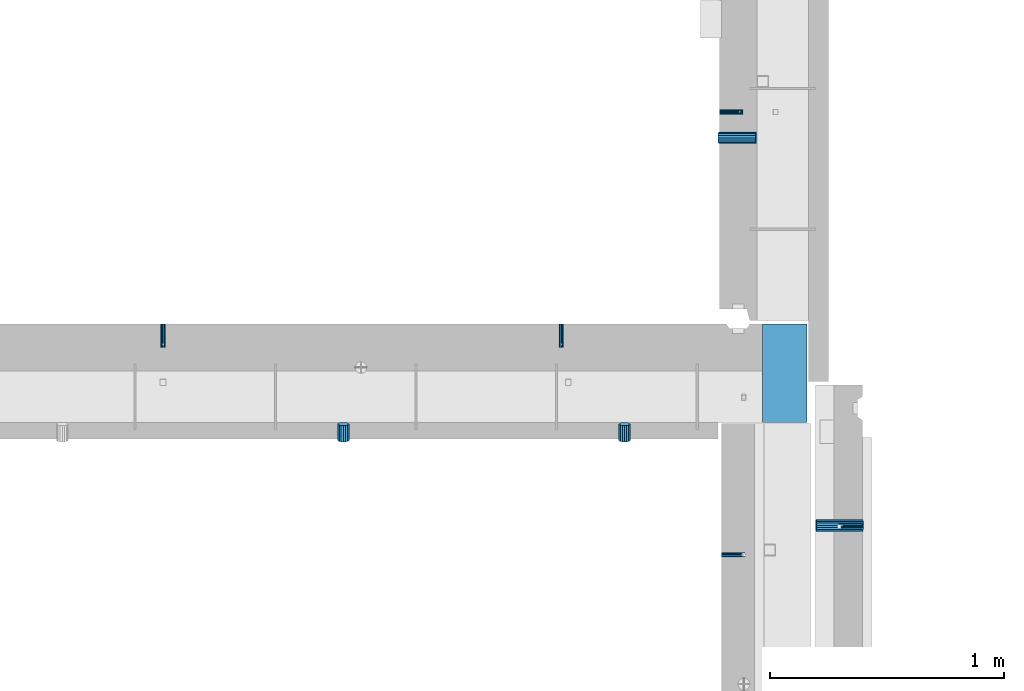
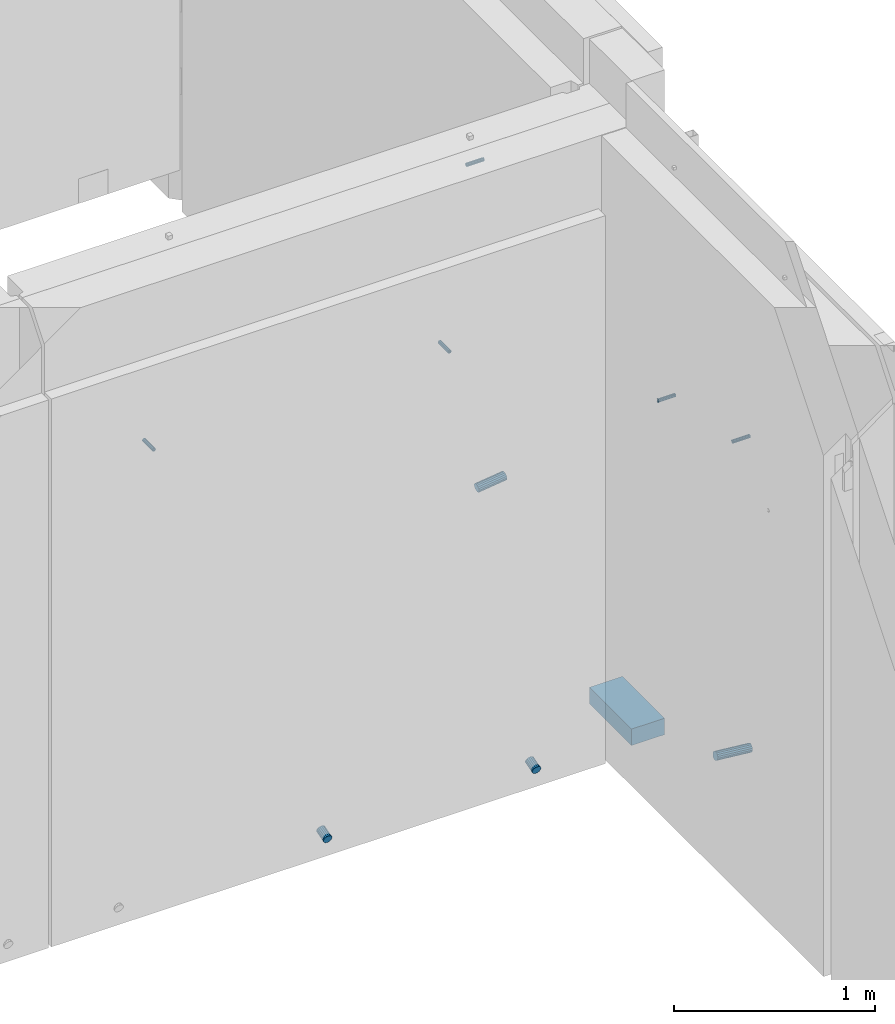
# One storey, part 111 of 264: 10 beams, 13 elements without a shape of their own.
"""IFC2X3 building model written with IfcOpenShell, lengths in millimetres."""

from ifc_helpers import new_model, si_unit, frame, origin_with_axes, place, context, subcontext, project, spatial, faceted_brep, material, type_object, element, aggregate, save


model = new_model("IFC2X3")

# Units and contexts
model_context = context("Model", 3, precision=1e-05, world=origin_with_axes())
body_context = subcontext(model_context, "Body", "Model", "MODEL_VIEW")
ifc_project = project(units=[si_unit("LENGTHUNIT", "METRE", prefix="MILLI"), si_unit("AREAUNIT", "SQUARE_METRE"), si_unit("VOLUMEUNIT", "CUBIC_METRE"), si_unit("MASSUNIT", "GRAM", prefix="KILO"), si_unit("TIMEUNIT", "SECOND"), si_unit("PLANEANGLEUNIT", "RADIAN"), si_unit("SOLIDANGLEUNIT", "STERADIAN"), si_unit("THERMODYNAMICTEMPERATUREUNIT", "DEGREE_CELSIUS"), si_unit("LUMINOUSINTENSITYUNIT", "LUMEN")], contexts=[model_context])

# Site, building, storey
site_placement = place(None, origin_with_axes())
site = spatial("IfcSite", under=ifc_project, at=site_placement, CompositionType="ELEMENT")
building_placement = place(site_placement, origin_with_axes())
building = spatial("IfcBuilding", under=site, at=building_placement, CompositionType="ELEMENT")
storey_placement = place(building_placement, origin_with_axes())
storey = spatial("IfcBuildingStorey", under=building, at=storey_placement, Name="K", CompositionType="ELEMENT", Elevation=0.0)

# Assemblies, beam
assembly_1_placement = place(storey_placement, origin_with_axes())
assembly_1 = element("IfcElementAssembly", 1, at=assembly_1_placement, inside=storey, AssemblyPlace="NOTDEFINED", PredefinedType="REINFORCEMENT_UNIT")
assembly_2_placement = place(assembly_1_placement, origin_with_axes())
assembly_2 = element("IfcElementAssembly", 2, at=assembly_2_placement, Name="Steel Assembly", AssemblyPlace="NOTDEFINED", PredefinedType="RIGID_FRAME")
ifc_material_1 = material(Name="STEEL/Steel_Undefined")
beam_type_1 = type_object("IfcBeamType", PredefinedType="NOTDEFINED")
beam_1_placement = place(assembly_2_placement, frame((35510.0000014901, 12319.9848274528, 79700.0030770672), z_axis=(0.0, 1.0, 0.0), x_axis=(-1.0, 3.00000001838171e-08, 0.0)))
beam_1 = element("IfcBeam", 3, at=beam_1_placement, type_object=beam_type_1, material=ifc_material_1, Name="M16", context=body_context, shape_type="Brep", body=[
    faceted_brep([(0.0, -8.49999999999272, -1.45519152283669e-11), (0.0, -7.36121593215648, 4.24999999998545), (100.000000000262, -7.36121593215648, 4.24999999998545), (100.000000000262, -8.49999999999272, -1.45519152283669e-11), (0.0, -4.24999999998545, 7.36121593216376), (100.000000000262, -4.24999999998545, 7.36121593216376), (0.0, 1.45519152283669e-11, 8.49999999998545), (100.000000000262, 1.45519152283669e-11, 8.49999999998545), (0.0, 4.25000000001455, 7.36121593216376), (100.000000000262, 4.25000000001455, 7.36121593216376), (0.0, 7.36121593217104, 4.24999999998545), (100.000000000262, 7.36121593217104, 4.24999999998545), (0.0, 8.50000000000728, 0.0), (100.000000000262, 8.50000000000728, 0.0), (0.0, 7.36121593217104, -4.25000000001455), (100.000000000262, 7.36121593217104, -4.25000000001455), (0.0, 4.25000000000728, -7.36121593219286), (100.000000000262, 4.25000000000728, -7.36121593219286), (0.0, 7.27595761418343e-12, -8.5), (100.000000000262, 7.27595761418343e-12, -8.5), (0.0, -4.24999999999272, -7.36121593217831), (100.000000000262, -4.24999999999272, -7.36121593217831), (0.0, -7.36121593215648, -4.25), (100.000000000262, -7.36121593215648, -4.25), (0.0, -10.4999999999927, -1.45519152283669e-11), (0.0, -9.09326673972828, -5.25000000001455), (100.000000000262, -9.09326673972828, -5.25000000001455), (100.000000000262, -10.4999999999927, -1.45519152283669e-11), (0.0, -5.24999999998545, -9.09326673974283), (100.000000000262, -5.24999999998545, -9.09326673974283), (0.0, 7.27595761418343e-12, -10.5), (100.000000000262, 7.27595761418343e-12, -10.5), (0.0, 5.25000000001455, -9.09326673975738), (100.000000000262, 5.25000000001455, -9.09326673975738), (0.0, 9.09326673975011, -5.25000000001455), (100.000000000262, 9.09326673975011, -5.25000000001455), (0.0, 10.5000000000073, -1.45519152283669e-11), (100.000000000262, 10.5000000000073, -1.45519152283669e-11), (0.0, 9.09326673975011, 5.25), (100.000000000262, 9.09326673975011, 5.25), (0.0, 5.25000000000728, 9.09326673972828), (100.000000000262, 5.25000000000728, 9.09326673972828), (0.0, 1.45519152283669e-11, 10.4999999999854), (100.000000000262, 1.45519152283669e-11, 10.4999999999854), (0.0, -5.24999999999272, 9.09326673972828), (100.000000000262, -5.24999999999272, 9.09326673972828), (0.0, -9.09326673972828, 5.24999999998545), (100.000000000262, -9.09326673972828, 5.24999999998545)], [[[0, 1, 2, 3]], [[1, 4, 5, 2]], [[4, 6, 7, 5]], [[6, 8, 9, 7]], [[8, 10, 11, 9]], [[10, 12, 13, 11]], [[12, 14, 15, 13]], [[14, 16, 17, 15]], [[16, 18, 19, 17]], [[18, 20, 21, 19]], [[20, 22, 23, 21]], [[22, 0, 3, 23]], [[24, 25, 26, 27]], [[25, 28, 29, 26]], [[28, 30, 31, 29]], [[30, 32, 33, 31]], [[32, 34, 35, 33]], [[34, 36, 37, 35]], [[36, 38, 39, 37]], [[38, 40, 41, 39]], [[40, 42, 43, 41]], [[42, 44, 45, 43]], [[44, 46, 47, 45]], [[46, 24, 27, 47]], [[29, 31, 33, 35, 37, 39, 41, 43, 45, 47, 27, 26], [5, 7, 9, 11, 13, 15, 17, 19, 21, 23, 3, 2]], [[46, 44, 42, 40, 38, 36, 34, 32, 30, 28, 25, 24], [22, 20, 18, 16, 14, 12, 10, 8, 6, 4, 1, 0]]]),
])
aggregate(assembly_2, [beam_1])

# Assemblies, beams
assembly_3_placement = place(storey_placement, origin_with_axes())
assembly_3 = element("IfcElementAssembly", 4, at=assembly_3_placement, inside=storey, AssemblyPlace="NOTDEFINED", PredefinedType="REINFORCEMENT_UNIT")
assembly_4_placement = place(assembly_3_placement, origin_with_axes())
assembly_4 = element("IfcElementAssembly", 5, at=assembly_4_placement, Name="Steel Assembly", AssemblyPlace="NOTDEFINED", PredefinedType="RIGID_FRAME")
beam_2_placement = place(assembly_4_placement, frame((32525.0017535345, 13180.0018965848, 80200.0), z_axis=(-1.0, 3.00000001838171e-08, 0.0), x_axis=(0.0, -1.0, 0.0)))
beam_2 = element("IfcBeam", 6, at=beam_2_placement, type_object=beam_type_1, material=ifc_material_1, Name="M16", context=body_context, shape_type="Brep", body=[
    faceted_brep([(0.0, -8.49999999999272, -1.45519152283669e-11), (0.0, -7.36121593215648, 4.24999999998545), (100.000000000262, -7.36121593215648, 4.24999999998545), (100.000000000262, -8.49999999999272, -1.45519152283669e-11), (0.0, -4.24999999998545, 7.36121593216376), (100.000000000262, -4.24999999998545, 7.36121593216376), (0.0, 1.45519152283669e-11, 8.49999999998545), (100.000000000262, 1.45519152283669e-11, 8.49999999998545), (0.0, 4.25000000001455, 7.36121593216376), (100.000000000262, 4.25000000001455, 7.36121593216376), (0.0, 7.36121593217104, 4.24999999998545), (100.000000000262, 7.36121593217104, 4.24999999998545), (0.0, 8.50000000000728, 0.0), (100.000000000262, 8.50000000000728, 0.0), (0.0, 7.36121593217104, -4.25000000001455), (100.000000000262, 7.36121593217104, -4.25000000001455), (0.0, 4.25000000000728, -7.36121593219286), (100.000000000262, 4.25000000000728, -7.36121593219286), (0.0, 7.27595761418343e-12, -8.5), (100.000000000262, 7.27595761418343e-12, -8.5), (0.0, -4.24999999999272, -7.36121593217831), (100.000000000262, -4.24999999999272, -7.36121593217831), (0.0, -7.36121593215648, -4.25), (100.000000000262, -7.36121593215648, -4.25), (0.0, -10.4999999999927, -1.45519152283669e-11), (0.0, -9.09326673972828, -5.25000000001455), (100.000000000262, -9.09326673972828, -5.25000000001455), (100.000000000262, -10.4999999999927, -1.45519152283669e-11), (0.0, -5.24999999998545, -9.09326673974283), (100.000000000262, -5.24999999998545, -9.09326673974283), (0.0, 7.27595761418343e-12, -10.5), (100.000000000262, 7.27595761418343e-12, -10.5), (0.0, 5.25000000001455, -9.09326673975738), (100.000000000262, 5.25000000001455, -9.09326673975738), (0.0, 9.09326673975011, -5.25000000001455), (100.000000000262, 9.09326673975011, -5.25000000001455), (0.0, 10.5000000000073, -1.45519152283669e-11), (100.000000000262, 10.5000000000073, -1.45519152283669e-11), (0.0, 9.09326673975011, 5.25), (100.000000000262, 9.09326673975011, 5.25), (0.0, 5.25000000000728, 9.09326673972828), (100.000000000262, 5.25000000000728, 9.09326673972828), (0.0, 1.45519152283669e-11, 10.4999999999854), (100.000000000262, 1.45519152283669e-11, 10.4999999999854), (0.0, -5.24999999999272, 9.09326673972828), (100.000000000262, -5.24999999999272, 9.09326673972828), (0.0, -9.09326673972828, 5.24999999998545), (100.000000000262, -9.09326673972828, 5.24999999998545)], [[[0, 1, 2, 3]], [[1, 4, 5, 2]], [[4, 6, 7, 5]], [[6, 8, 9, 7]], [[8, 10, 11, 9]], [[10, 12, 13, 11]], [[12, 14, 15, 13]], [[14, 16, 17, 15]], [[16, 18, 19, 17]], [[18, 20, 21, 19]], [[20, 22, 23, 21]], [[22, 0, 3, 23]], [[24, 25, 26, 27]], [[25, 28, 29, 26]], [[28, 30, 31, 29]], [[30, 32, 33, 31]], [[32, 34, 35, 33]], [[34, 36, 37, 35]], [[36, 38, 39, 37]], [[38, 40, 41, 39]], [[40, 42, 43, 41]], [[42, 44, 45, 43]], [[44, 46, 47, 45]], [[46, 24, 27, 47]], [[29, 31, 33, 35, 37, 39, 41, 43, 45, 47, 27, 26], [5, 7, 9, 11, 13, 15, 17, 19, 21, 23, 3, 2]], [[46, 44, 42, 40, 38, 36, 34, 32, 30, 28, 25, 24], [22, 20, 18, 16, 14, 12, 10, 8, 6, 4, 1, 0]]]),
])
aggregate(assembly_4, [beam_2])
assembly_5_placement = place(assembly_3_placement, origin_with_axes())
assembly_5 = element("IfcElementAssembly", 7, at=assembly_5_placement, Name="Steel Assembly", AssemblyPlace="NOTDEFINED", PredefinedType="RIGID_FRAME")
beam_3_placement = place(assembly_5_placement, frame((34225.0017535345, 13180.0018965848, 80200.0), z_axis=(1.0, 0.0, 0.0), x_axis=(0.0, -1.0, 0.0)))
beam_3 = element("IfcBeam", 8, at=beam_3_placement, type_object=beam_type_1, material=ifc_material_1, Name="M16", context=body_context, shape_type="Brep", body=[
    faceted_brep([(0.0, -8.49999999999272, -1.45519152283669e-11), (0.0, -7.36121593215648, 4.24999999998545), (100.000000000262, -7.36121593215648, 4.24999999998545), (100.000000000262, -8.49999999999272, -1.45519152283669e-11), (0.0, -4.24999999998545, 7.36121593216376), (100.000000000262, -4.24999999998545, 7.36121593216376), (0.0, 1.45519152283669e-11, 8.49999999998545), (100.000000000262, 1.45519152283669e-11, 8.49999999998545), (0.0, 4.25000000001455, 7.36121593216376), (100.000000000262, 4.25000000001455, 7.36121593216376), (0.0, 7.36121593217104, 4.24999999998545), (100.000000000262, 7.36121593217104, 4.24999999998545), (0.0, 8.50000000000728, 0.0), (100.000000000262, 8.50000000000728, 0.0), (0.0, 7.36121593217104, -4.25000000001455), (100.000000000262, 7.36121593217104, -4.25000000001455), (0.0, 4.25000000000728, -7.36121593219286), (100.000000000262, 4.25000000000728, -7.36121593219286), (0.0, 7.27595761418343e-12, -8.5), (100.000000000262, 7.27595761418343e-12, -8.5), (0.0, -4.24999999999272, -7.36121593217831), (100.000000000262, -4.24999999999272, -7.36121593217831), (0.0, -7.36121593215648, -4.25), (100.000000000262, -7.36121593215648, -4.25), (0.0, -10.4999999999927, -1.45519152283669e-11), (0.0, -9.09326673972828, -5.25000000001455), (100.000000000262, -9.09326673972828, -5.25000000001455), (100.000000000262, -10.4999999999927, -1.45519152283669e-11), (0.0, -5.24999999998545, -9.09326673974283), (100.000000000262, -5.24999999998545, -9.09326673974283), (0.0, 7.27595761418343e-12, -10.5), (100.000000000262, 7.27595761418343e-12, -10.5), (0.0, 5.25000000001455, -9.09326673975738), (100.000000000262, 5.25000000001455, -9.09326673975738), (0.0, 9.09326673975011, -5.25000000001455), (100.000000000262, 9.09326673975011, -5.25000000001455), (0.0, 10.5000000000073, -1.45519152283669e-11), (100.000000000262, 10.5000000000073, -1.45519152283669e-11), (0.0, 9.09326673975011, 5.25), (100.000000000262, 9.09326673975011, 5.25), (0.0, 5.25000000000728, 9.09326673972828), (100.000000000262, 5.25000000000728, 9.09326673972828), (0.0, 1.45519152283669e-11, 10.4999999999854), (100.000000000262, 1.45519152283669e-11, 10.4999999999854), (0.0, -5.24999999999272, 9.09326673972828), (100.000000000262, -5.24999999999272, 9.09326673972828), (0.0, -9.09326673972828, 5.24999999998545), (100.000000000262, -9.09326673972828, 5.24999999998545)], [[[0, 1, 2, 3]], [[1, 4, 5, 2]], [[4, 6, 7, 5]], [[6, 8, 9, 7]], [[8, 10, 11, 9]], [[10, 12, 13, 11]], [[12, 14, 15, 13]], [[14, 16, 17, 15]], [[16, 18, 19, 17]], [[18, 20, 21, 19]], [[20, 22, 23, 21]], [[22, 0, 3, 23]], [[24, 25, 26, 27]], [[25, 28, 29, 26]], [[28, 30, 31, 29]], [[30, 32, 33, 31]], [[32, 34, 35, 33]], [[34, 36, 37, 35]], [[36, 38, 39, 37]], [[38, 40, 41, 39]], [[40, 42, 43, 41]], [[42, 44, 45, 43]], [[44, 46, 47, 45]], [[46, 24, 27, 47]], [[29, 31, 33, 35, 37, 39, 41, 43, 45, 47, 27, 26], [5, 7, 9, 11, 13, 15, 17, 19, 21, 23, 3, 2]], [[46, 44, 42, 40, 38, 36, 34, 32, 30, 28, 25, 24], [22, 20, 18, 16, 14, 12, 10, 8, 6, 4, 1, 0]]]),
])
aggregate(assembly_5, [beam_3])

# Assemblies, beam
assembly_6_placement = place(storey_placement, origin_with_axes())
assembly_6 = element("IfcElementAssembly", 9, at=assembly_6_placement, inside=storey, AssemblyPlace="NOTDEFINED", PredefinedType="REINFORCEMENT_UNIT")
assembly_7_placement = place(assembly_6_placement, origin_with_axes())
assembly_7 = element("IfcElementAssembly", 10, at=assembly_7_placement, Name="Steel Assembly", AssemblyPlace="NOTDEFINED", PredefinedType="RIGID_FRAME")
aggregate(assembly_6, [assembly_7])
beam_4_placement = place(assembly_7_placement, frame((34910.0024573137, 12195.0054710417, 80200.0), z_axis=(0.0, 1.0, 0.0), x_axis=(1.0, 0.0, 0.0)))
beam_4 = element("IfcBeam", 11, at=beam_4_placement, type_object=beam_type_1, material=ifc_material_1, Name="M16", context=body_context, shape_type="Brep", body=[
    faceted_brep([(0.0, -8.49999999999272, -1.45519152283669e-11), (0.0, -7.36121593215648, 4.24999999998545), (100.000000000262, -7.36121593215648, 4.24999999998545), (100.000000000262, -8.49999999999272, -1.45519152283669e-11), (0.0, -4.24999999998545, 7.36121593216376), (100.000000000262, -4.24999999998545, 7.36121593216376), (0.0, 1.45519152283669e-11, 8.49999999998545), (100.000000000262, 1.45519152283669e-11, 8.49999999998545), (0.0, 4.25000000001455, 7.36121593216376), (100.000000000262, 4.25000000001455, 7.36121593216376), (0.0, 7.36121593217104, 4.24999999998545), (100.000000000262, 7.36121593217104, 4.24999999998545), (0.0, 8.50000000000728, 0.0), (100.000000000262, 8.50000000000728, 0.0), (0.0, 7.36121593217104, -4.25000000001455), (100.000000000262, 7.36121593217104, -4.25000000001455), (0.0, 4.25000000000728, -7.36121593219286), (100.000000000262, 4.25000000000728, -7.36121593219286), (0.0, 7.27595761418343e-12, -8.5), (100.000000000262, 7.27595761418343e-12, -8.5), (0.0, -4.24999999999272, -7.36121593217831), (100.000000000262, -4.24999999999272, -7.36121593217831), (0.0, -7.36121593215648, -4.25), (100.000000000262, -7.36121593215648, -4.25), (0.0, -10.4999999999927, -1.45519152283669e-11), (0.0, -9.09326673972828, -5.25000000001455), (100.000000000262, -9.09326673972828, -5.25000000001455), (100.000000000262, -10.4999999999927, -1.45519152283669e-11), (0.0, -5.24999999998545, -9.09326673974283), (100.000000000262, -5.24999999998545, -9.09326673974283), (0.0, 7.27595761418343e-12, -10.5), (100.000000000262, 7.27595761418343e-12, -10.5), (0.0, 5.25000000001455, -9.09326673975738), (100.000000000262, 5.25000000001455, -9.09326673975738), (0.0, 9.09326673975011, -5.25000000001455), (100.000000000262, 9.09326673975011, -5.25000000001455), (0.0, 10.5000000000073, -1.45519152283669e-11), (100.000000000262, 10.5000000000073, -1.45519152283669e-11), (0.0, 9.09326673975011, 5.25), (100.000000000262, 9.09326673975011, 5.25), (0.0, 5.25000000000728, 9.09326673972828), (100.000000000262, 5.25000000000728, 9.09326673972828), (0.0, 1.45519152283669e-11, 10.4999999999854), (100.000000000262, 1.45519152283669e-11, 10.4999999999854), (0.0, -5.24999999999272, 9.09326673972828), (100.000000000262, -5.24999999999272, 9.09326673972828), (0.0, -9.09326673972828, 5.24999999998545), (100.000000000262, -9.09326673972828, 5.24999999998545)], [[[0, 1, 2, 3]], [[1, 4, 5, 2]], [[4, 6, 7, 5]], [[6, 8, 9, 7]], [[8, 10, 11, 9]], [[10, 12, 13, 11]], [[12, 14, 15, 13]], [[14, 16, 17, 15]], [[16, 18, 19, 17]], [[18, 20, 21, 19]], [[20, 22, 23, 21]], [[22, 0, 3, 23]], [[24, 25, 26, 27]], [[25, 28, 29, 26]], [[28, 30, 31, 29]], [[30, 32, 33, 31]], [[32, 34, 35, 33]], [[34, 36, 37, 35]], [[36, 38, 39, 37]], [[38, 40, 41, 39]], [[40, 42, 43, 41]], [[42, 44, 45, 43]], [[44, 46, 47, 45]], [[46, 24, 27, 47]], [[29, 31, 33, 35, 37, 39, 41, 43, 45, 47, 27, 26], [5, 7, 9, 11, 13, 15, 17, 19, 21, 23, 3, 2]], [[46, 44, 42, 40, 38, 36, 34, 32, 30, 28, 25, 24], [22, 20, 18, 16, 14, 12, 10, 8, 6, 4, 1, 0]]]),
])
aggregate(assembly_7, [beam_4])

assembly_8_placement = place(storey_placement, origin_with_axes())
assembly_8 = element("IfcElementAssembly", 12, at=assembly_8_placement, inside=storey, AssemblyPlace="NOTDEFINED", PredefinedType="REINFORCEMENT_UNIT")
assembly_9_placement = place(assembly_8_placement, origin_with_axes())
assembly_9 = element("IfcElementAssembly", 13, at=assembly_9_placement, Name="Steel Assembly", AssemblyPlace="NOTDEFINED", PredefinedType="RIGID_FRAME")
beam_5_placement = place(assembly_9_placement, frame((34900.0015572397, 14084.9987815364, 80490.0), z_axis=(0.0, -1.0, 0.0), x_axis=(1.0, 0.0, 0.0)))
beam_5 = element("IfcBeam", 14, at=beam_5_placement, type_object=beam_type_1, material=ifc_material_1, Name="M16", context=body_context, shape_type="Brep", body=[
    faceted_brep([(0.0, -8.49999999999272, -1.45519152283669e-11), (0.0, -7.36121593215648, 4.24999999998545), (100.000000000262, -7.36121593215648, 4.24999999998545), (100.000000000262, -8.49999999999272, -1.45519152283669e-11), (0.0, -4.24999999998545, 7.36121593216376), (100.000000000262, -4.24999999998545, 7.36121593216376), (0.0, 1.45519152283669e-11, 8.49999999998545), (100.000000000262, 1.45519152283669e-11, 8.49999999998545), (0.0, 4.25000000001455, 7.36121593216376), (100.000000000262, 4.25000000001455, 7.36121593216376), (0.0, 7.36121593217104, 4.24999999998545), (100.000000000262, 7.36121593217104, 4.24999999998545), (0.0, 8.50000000000728, 0.0), (100.000000000262, 8.50000000000728, 0.0), (0.0, 7.36121593217104, -4.25000000001455), (100.000000000262, 7.36121593217104, -4.25000000001455), (0.0, 4.25000000000728, -7.36121593219286), (100.000000000262, 4.25000000000728, -7.36121593219286), (0.0, 7.27595761418343e-12, -8.5), (100.000000000262, 7.27595761418343e-12, -8.5), (0.0, -4.24999999999272, -7.36121593217831), (100.000000000262, -4.24999999999272, -7.36121593217831), (0.0, -7.36121593215648, -4.25), (100.000000000262, -7.36121593215648, -4.25), (0.0, -10.4999999999927, -1.45519152283669e-11), (0.0, -9.09326673972828, -5.25000000001455), (100.000000000262, -9.09326673972828, -5.25000000001455), (100.000000000262, -10.4999999999927, -1.45519152283669e-11), (0.0, -5.24999999998545, -9.09326673974283), (100.000000000262, -5.24999999998545, -9.09326673974283), (0.0, 7.27595761418343e-12, -10.5), (100.000000000262, 7.27595761418343e-12, -10.5), (0.0, 5.25000000001455, -9.09326673975738), (100.000000000262, 5.25000000001455, -9.09326673975738), (0.0, 9.09326673975011, -5.25000000001455), (100.000000000262, 9.09326673975011, -5.25000000001455), (0.0, 10.5000000000073, -1.45519152283669e-11), (100.000000000262, 10.5000000000073, -1.45519152283669e-11), (0.0, 9.09326673975011, 5.25), (100.000000000262, 9.09326673975011, 5.25), (0.0, 5.25000000000728, 9.09326673972828), (100.000000000262, 5.25000000000728, 9.09326673972828), (0.0, 1.45519152283669e-11, 10.4999999999854), (100.000000000262, 1.45519152283669e-11, 10.4999999999854), (0.0, -5.24999999999272, 9.09326673972828), (100.000000000262, -5.24999999999272, 9.09326673972828), (0.0, -9.09326673972828, 5.24999999998545), (100.000000000262, -9.09326673972828, 5.24999999998545)], [[[0, 1, 2, 3]], [[1, 4, 5, 2]], [[4, 6, 7, 5]], [[6, 8, 9, 7]], [[8, 10, 11, 9]], [[10, 12, 13, 11]], [[12, 14, 15, 13]], [[14, 16, 17, 15]], [[16, 18, 19, 17]], [[18, 20, 21, 19]], [[20, 22, 23, 21]], [[22, 0, 3, 23]], [[24, 25, 26, 27]], [[25, 28, 29, 26]], [[28, 30, 31, 29]], [[30, 32, 33, 31]], [[32, 34, 35, 33]], [[34, 36, 37, 35]], [[36, 38, 39, 37]], [[38, 40, 41, 39]], [[40, 42, 43, 41]], [[42, 44, 45, 43]], [[44, 46, 47, 45]], [[46, 24, 27, 47]], [[29, 31, 33, 35, 37, 39, 41, 43, 45, 47, 27, 26], [5, 7, 9, 11, 13, 15, 17, 19, 21, 23, 3, 2]], [[46, 44, 42, 40, 38, 36, 34, 32, 30, 28, 25, 24], [22, 20, 18, 16, 14, 12, 10, 8, 6, 4, 1, 0]]]),
])
aggregate(assembly_9, [beam_5])

# Assembly
assembly_10_placement = place(assembly_1_placement, origin_with_axes())
assembly_10 = element("IfcElementAssembly", 15, at=assembly_10_placement, Name="Steel Assembly", AssemblyPlace="NOTDEFINED", PredefinedType="NOTDEFINED")

aggregate(assembly_1, [assembly_2, assembly_10])

# Beam
ifc_material_2 = material()
beam_type_2 = type_object("IfcBeamType", Name="D50", PredefinedType="NOTDEFINED")
beam_6_placement = place(assembly_10_placement, frame((35312.4900502895, 12319.99189658, 77824.8759297562), z_axis=(0.0, 1.0, 0.0), x_axis=(0.995037190209988, 0.0, -0.0995037190210061)))
beam_6 = element("IfcBeam", 16, at=beam_6_placement, type_object=beam_type_2, material=ifc_material_2, ObjectType="D50", context=body_context, shape_type="Brep", body=[
    faceted_brep([(0.0, -25.0, 0.0), (-3.63797880709171e-12, -23.0969883127837, -9.56708580912891), (200.997512422258, -23.0969883127982, -9.56708580912709), (200.997512422255, -25.0, 0.0), (-3.63797880709171e-12, -17.6776695296576, -17.6776695296649), (200.997512422262, -17.6776695296867, -17.6776695296639), (-1.09139364212751e-11, -9.56708580913255, -23.0969883127837), (200.997512422262, -9.5670858091471, -23.0969883127818), (-1.09139364212751e-11, 0.0, -25.0), (200.997512422258, -1.45519152283669e-11, -25.0), (-1.09139364212751e-11, 9.56708580913255, -23.0969883127837), (200.997512422262, 9.56708580910345, -23.0969883127818), (-3.63797880709171e-12, 17.6776695296576, -17.6776695296649), (200.997512422262, 17.677669529643, -17.6776695296639), (-3.63797880709171e-12, 23.0969883127837, -9.56708580912891), (200.997512422262, 23.0969883127691, -9.56708580912709), (0.0, 25.0, 0.0), (200.997512422266, 24.9999999999854, 0.0), (7.27595761418343e-12, 23.0969883127837, 9.56708580912891), (200.997512422262, 23.0969883127691, 9.56708580912709), (7.27595761418343e-12, 17.6776695296576, 17.6776695296649), (200.997512422262, 17.677669529643, 17.6776695296639), (1.45519152283669e-11, 9.56708580913255, 23.0969883127837), (200.997512422262, 9.56708580910345, 23.0969883127818), (1.09139364212751e-11, 0.0, 25.0), (200.997512422258, -1.45519152283669e-11, 25.0), (1.45519152283669e-11, -9.56708580913255, 23.0969883127837), (200.997512422262, -9.5670858091471, 23.0969883127818), (7.27595761418343e-12, -17.6776695296576, 17.6776695296649), (200.997512422262, -17.6776695296867, 17.6776695296639), (7.27595761418343e-12, -23.0969883127837, 9.56708580912891), (200.997512422258, -23.0969883127982, 9.56708580912709)], [[[0, 1, 2, 3]], [[1, 4, 5, 2]], [[4, 6, 7, 5]], [[6, 8, 9, 7]], [[8, 10, 11, 9]], [[10, 12, 13, 11]], [[12, 14, 15, 13]], [[14, 16, 17, 15]], [[16, 18, 19, 17]], [[18, 20, 21, 19]], [[20, 22, 23, 21]], [[22, 24, 25, 23]], [[24, 26, 27, 25]], [[26, 28, 29, 27]], [[28, 30, 31, 29]], [[30, 0, 3, 31]], [[5, 7, 9, 11, 13, 15, 17, 19, 21, 23, 25, 27, 29, 31, 3, 2]], [[30, 28, 26, 24, 22, 20, 18, 16, 14, 12, 10, 8, 6, 4, 1, 0]]]),
])

aggregate(assembly_10, [beam_6])

# Assembly, beam
assembly_11_placement = place(assembly_3_placement, origin_with_axes())
assembly_11 = element("IfcElementAssembly", 17, at=assembly_11_placement, Name="Steel Assembly", AssemblyPlace="NOTDEFINED", PredefinedType="NOTDEFINED")
beam_7_placement = place(assembly_11_placement, frame((33295.0024573137, 12753.1338683873, 77824.0380986929), z_axis=(1.0, 0.0, 0.0), x_axis=(0.0, -0.96152394764082, -0.274721127897391)))
beam_7 = element("IfcBeam", 18, at=beam_7_placement, type_object=beam_type_2, material=ifc_material_2, ObjectType="D50", context=body_context, shape_type="Brep", body=[
    faceted_brep([(0.0, -25.0, 0.0), (-3.63797880709171e-12, -23.0969883127837, -9.56708580912891), (72.8010988927999, -23.0969883127982, -9.56708580912891), (72.8010988927999, -25.0, 0.0), (-3.63797880709171e-12, -17.6776695296576, -17.6776695296649), (72.8010988927927, -17.6776695296576, -17.6776695296649), (-1.09139364212751e-11, -9.56708580913255, -23.0969883127837), (72.8010988927927, -9.56708580913255, -23.0969883127837), (-1.09139364212751e-11, 0.0, -25.0), (72.8010988927927, 0.0, -25.0), (-1.09139364212751e-11, 9.56708580913255, -23.0969883127837), (72.8010988927999, 9.56708580913255, -23.0969883127837), (-3.63797880709171e-12, 17.6776695296576, -17.6776695296649), (72.8010988927999, 17.6776695296721, -17.6776695296649), (-3.63797880709171e-12, 23.0969883127837, -9.56708580912891), (72.8010988927999, 23.0969883127837, -9.56708580912891), (0.0, 25.0, 0.0), (72.8010988927999, 25.0, 0.0), (7.27595761418343e-12, 23.0969883127837, 9.56708580912891), (72.8010988927999, 23.0969883127837, 9.56708580912891), (7.27595761418343e-12, 17.6776695296576, 17.6776695296649), (72.8010988927999, 17.6776695296721, 17.6776695296649), (1.45519152283669e-11, 9.56708580913255, 23.0969883127837), (72.8010988927999, 9.56708580913255, 23.0969883127837), (1.09139364212751e-11, 0.0, 25.0), (72.8010988927927, 0.0, 25.0), (1.45519152283669e-11, -9.56708580913255, 23.0969883127837), (72.8010988927927, -9.56708580913255, 23.0969883127837), (7.27595761418343e-12, -17.6776695296576, 17.6776695296649), (72.8010988927927, -17.6776695296576, 17.6776695296649), (7.27595761418343e-12, -23.0969883127837, 9.56708580912891), (72.8010988927999, -23.0969883127982, 9.56708580912891)], [[[0, 1, 2, 3]], [[1, 4, 5, 2]], [[4, 6, 7, 5]], [[6, 8, 9, 7]], [[8, 10, 11, 9]], [[10, 12, 13, 11]], [[12, 14, 15, 13]], [[14, 16, 17, 15]], [[16, 18, 19, 17]], [[18, 20, 21, 19]], [[20, 22, 23, 21]], [[22, 24, 25, 23]], [[24, 26, 27, 25]], [[26, 28, 29, 27]], [[28, 30, 31, 29]], [[30, 0, 3, 31]], [[5, 7, 9, 11, 13, 15, 17, 19, 21, 23, 25, 27, 29, 31, 3, 2]], [[30, 28, 26, 24, 22, 20, 18, 16, 14, 12, 10, 8, 6, 4, 1, 0]]]),
])
aggregate(assembly_11, [beam_7])

assembly_12_placement = place(assembly_3_placement, origin_with_axes())
assembly_12 = element("IfcElementAssembly", 19, at=assembly_12_placement, Name="Steel Assembly", AssemblyPlace="NOTDEFINED", PredefinedType="NOTDEFINED")
beam_8_placement = place(assembly_12_placement, frame((34495.0024573137, 12753.1338683873, 77824.0380986929), z_axis=(1.0, 0.0, 0.0), x_axis=(0.0, -0.96152394764082, -0.274721127897391)))
beam_8 = element("IfcBeam", 20, at=beam_8_placement, type_object=beam_type_2, material=ifc_material_2, ObjectType="D50", context=body_context, shape_type="Brep", body=[
    faceted_brep([(0.0, -25.0, 0.0), (-3.63797880709171e-12, -23.0969883127837, -9.56708580912891), (72.8010988927999, -23.0969883127982, -9.56708580912891), (72.8010988927999, -25.0, 0.0), (-3.63797880709171e-12, -17.6776695296576, -17.6776695296649), (72.8010988927927, -17.6776695296576, -17.6776695296649), (-1.09139364212751e-11, -9.56708580913255, -23.0969883127837), (72.8010988927927, -9.56708580913255, -23.0969883127837), (-1.09139364212751e-11, 0.0, -25.0), (72.8010988927927, 0.0, -25.0), (-1.09139364212751e-11, 9.56708580913255, -23.0969883127837), (72.8010988927999, 9.56708580913255, -23.0969883127837), (-3.63797880709171e-12, 17.6776695296576, -17.6776695296649), (72.8010988927999, 17.6776695296721, -17.6776695296649), (-3.63797880709171e-12, 23.0969883127837, -9.56708580912891), (72.8010988927999, 23.0969883127837, -9.56708580912891), (0.0, 25.0, 0.0), (72.8010988927999, 25.0, 0.0), (7.27595761418343e-12, 23.0969883127837, 9.56708580912891), (72.8010988927999, 23.0969883127837, 9.56708580912891), (7.27595761418343e-12, 17.6776695296576, 17.6776695296649), (72.8010988927999, 17.6776695296721, 17.6776695296649), (1.45519152283669e-11, 9.56708580913255, 23.0969883127837), (72.8010988927999, 9.56708580913255, 23.0969883127837), (1.09139364212751e-11, 0.0, 25.0), (72.8010988927927, 0.0, 25.0), (1.45519152283669e-11, -9.56708580913255, 23.0969883127837), (72.8010988927927, -9.56708580913255, 23.0969883127837), (7.27595761418343e-12, -17.6776695296576, 17.6776695296649), (72.8010988927927, -17.6776695296576, 17.6776695296649), (7.27595761418343e-12, -23.0969883127837, 9.56708580912891), (72.8010988927999, -23.0969883127982, 9.56708580912891)], [[[0, 1, 2, 3]], [[1, 4, 5, 2]], [[4, 6, 7, 5]], [[6, 8, 9, 7]], [[8, 10, 11, 9]], [[10, 12, 13, 11]], [[12, 14, 15, 13]], [[14, 16, 17, 15]], [[16, 18, 19, 17]], [[18, 20, 21, 19]], [[20, 22, 23, 21]], [[22, 24, 25, 23]], [[24, 26, 27, 25]], [[26, 28, 29, 27]], [[28, 30, 31, 29]], [[30, 0, 3, 31]], [[5, 7, 9, 11, 13, 15, 17, 19, 21, 23, 25, 27, 29, 31, 3, 2]], [[30, 28, 26, 24, 22, 20, 18, 16, 14, 12, 10, 8, 6, 4, 1, 0]]]),
])
aggregate(assembly_12, [beam_8])

# Assembly
assembly_13_placement = place(assembly_8_placement, origin_with_axes())
assembly_13 = element("IfcElementAssembly", 21, at=assembly_13_placement, Name="Steel Assembly", AssemblyPlace="NOTDEFINED", PredefinedType="NOTDEFINED")

aggregate(assembly_8, [assembly_9, assembly_13])

# Beam
beam_9_placement = place(assembly_13_placement, frame((35056.9010488257, 13975.0003059587, 78614.8069469184), z_axis=(0.0, 1.0, 0.0), x_axis=(-0.99227787666731, -6.32999999219281e-07, -0.124034734958453)))
beam_9 = element("IfcBeam", 22, at=beam_9_placement, type_object=beam_type_2, material=ifc_material_2, ObjectType="D50", context=body_context, shape_type="Brep", body=[
    faceted_brep([(0.0, -25.0, 0.0), (-3.63797880709171e-12, -23.0969883127837, -9.56708580912891), (161.245154974295, -23.0969883127982, -9.56708580912891), (161.245154970162, -25.0000000000146, -3.63797880709171e-12), (-3.63797880709171e-12, -17.6776695296576, -17.6776695296649), (161.245154977802, -17.6776695296721, -17.6776695296576), (-1.09139364212751e-11, -9.56708580913255, -23.0969883127837), (161.245154980144, -9.56708580913255, -23.0969883127837), (-1.09139364212751e-11, 0.0, -25.0), (161.245154980967, -1.45519152283669e-11, -25.0), (-1.09139364212751e-11, 9.56708580913255, -23.0969883127837), (161.245154980144, 9.567085809118, -23.09698831278), (-3.63797880709171e-12, 17.6776695296576, -17.6776695296649), (161.245154977802, 17.6776695296576, -17.6776695296612), (-3.63797880709171e-12, 23.0969883127837, -9.56708580912891), (161.245154974295, 23.0969883127691, -9.56708580912891), (0.0, 25.0, 0.0), (161.245154970158, 25.0, 3.63797880709171e-12), (7.27595761418343e-12, 23.0969883127837, 9.56708580912891), (161.245154966022, 23.0969883127691, 9.56708580912891), (7.27595761418343e-12, 17.6776695296576, 17.6776695296649), (161.245154962515, 17.677669529643, 17.6776695296649), (1.45519152283669e-11, 9.56708580913255, 23.0969883127837), (161.245154960172, 9.567085809118, 23.09698831278), (1.09139364212751e-11, 0.0, 25.0), (161.24515495935, -1.45519152283669e-11, 24.9999999999964), (1.45519152283669e-11, -9.56708580913255, 23.0969883127837), (161.245154960168, -9.56708580913255, 23.09698831278), (7.27595761418343e-12, -17.6776695296576, 17.6776695296649), (161.245154962515, -17.6776695296721, 17.6776695296685), (7.27595761418343e-12, -23.0969883127837, 9.56708580912891), (161.245154966022, -23.0969883127982, 9.56708580912527)], [[[0, 1, 2, 3]], [[1, 4, 5, 2]], [[4, 6, 7, 5]], [[6, 8, 9, 7]], [[8, 10, 11, 9]], [[10, 12, 13, 11]], [[12, 14, 15, 13]], [[14, 16, 17, 15]], [[16, 18, 19, 17]], [[18, 20, 21, 19]], [[20, 22, 23, 21]], [[22, 24, 25, 23]], [[24, 26, 27, 25]], [[26, 28, 29, 27]], [[28, 30, 31, 29]], [[30, 0, 3, 31]], [[5, 7, 9, 11, 13, 15, 17, 19, 21, 23, 25, 27, 29, 31, 3, 2]], [[30, 28, 26, 24, 22, 20, 18, 16, 14, 12, 10, 8, 6, 4, 1, 0]]]),
])

aggregate(assembly_13, [beam_9])

ifc_material_3 = material(Name="CONCRETE/C25/30")
beam_type_3 = type_object("IfcBeamType", PredefinedType="NOTDEFINED")
beam_10_placement = place(assembly_3_placement, frame((35180.0024573137, 13180.0018965848, 77750.0), z_axis=(0.0, 0.0, 1.0), x_axis=(0.0, -1.0, 0.0)))
beam_10 = element("IfcBeam", 23, at=beam_10_placement, type_object=beam_type_3, material=ifc_material_3, context=body_context, shape_type="Brep", body=[
    faceted_brep([(0.0, 95.0, -50.0), (0.0, 95.0, 50.0), (420.000000000004, 95.0, 50.0), (420.000000000004, 95.0, -50.0), (0.0, -95.0, 50.0), (420.000000000004, -95.0, 50.0), (0.0, -95.0, -50.0), (420.000000000004, -95.0, -50.0)], [[[0, 1, 2, 3]], [[1, 4, 5, 2]], [[4, 6, 7, 5]], [[6, 0, 3, 7]], [[5, 7, 3, 2]], [[6, 4, 1, 0]]]),
])

aggregate(assembly_3, [beam_10, assembly_4, assembly_5, assembly_11, assembly_12])

save(model, "model.ifc")
